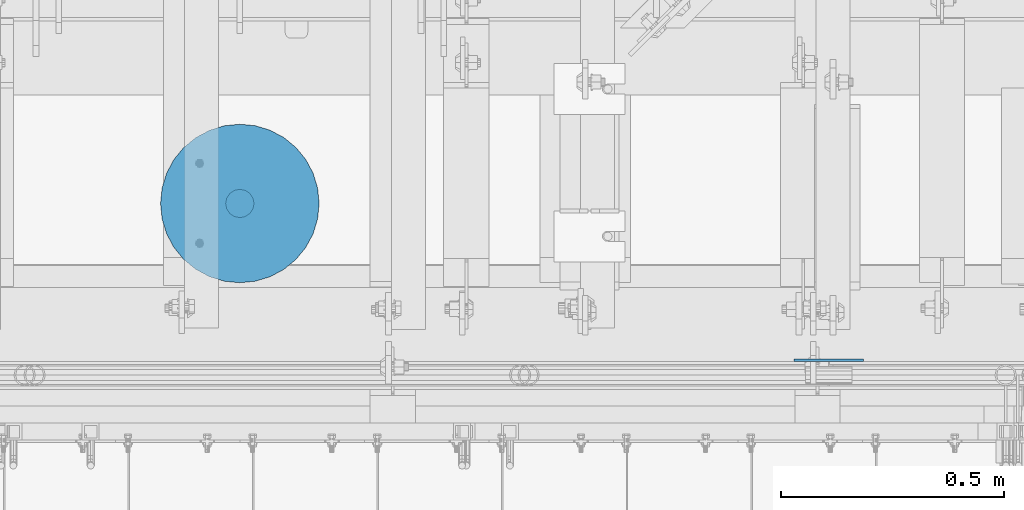
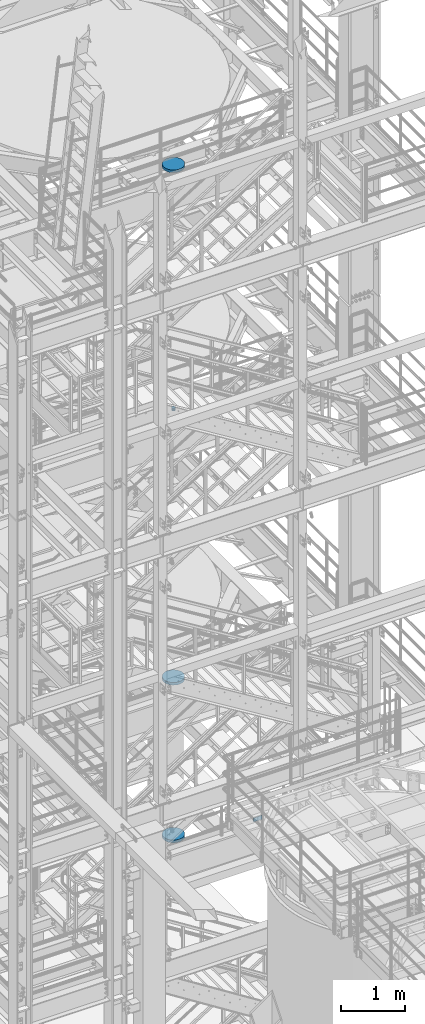
# One storey, part 827 of 1876: 5 columns, 5 elements without a shape of their own.
"""IFC2X3 building model written with IfcOpenShell, lengths in millimetres."""

from ifc_helpers import new_model, si_unit, frame, origin_with_axes, place, context, subcontext, project, spatial, faceted_brep, material, type_object, element, aggregate, save


model = new_model("IFC2X3")

# Units and contexts
model_context = context("Model", 3, precision=1e-05, world=origin_with_axes())
body_context = subcontext(model_context, "Body", "Model", "MODEL_VIEW")
ifc_project = project(units=[si_unit("LENGTHUNIT", "METRE", prefix="MILLI"), si_unit("AREAUNIT", "SQUARE_METRE"), si_unit("VOLUMEUNIT", "CUBIC_METRE"), si_unit("MASSUNIT", "GRAM", prefix="KILO"), si_unit("TIMEUNIT", "SECOND"), si_unit("PLANEANGLEUNIT", "RADIAN"), si_unit("SOLIDANGLEUNIT", "STERADIAN"), si_unit("THERMODYNAMICTEMPERATUREUNIT", "DEGREE_CELSIUS"), si_unit("LUMINOUSINTENSITYUNIT", "LUMEN")], contexts=[model_context])

# Site, building, storey
site_placement = place(None, origin_with_axes())
site = spatial("IfcSite", under=ifc_project, at=site_placement, CompositionType="ELEMENT")
building_placement = place(site_placement, origin_with_axes())
building = spatial("IfcBuilding", under=site, at=building_placement, Name="Undefined", CompositionType="ELEMENT")
storey_placement = place(building_placement, origin_with_axes())
storey = spatial("IfcBuildingStorey", under=building, at=storey_placement, Name="Undefined", CompositionType="ELEMENT", Elevation=0.0)

# Assembly, column
assembly_1_placement = place(storey_placement, origin_with_axes())
assembly_1 = element("IfcElementAssembly", 1, at=assembly_1_placement, inside=storey, Name="RAIL", AssemblyPlace="NOTDEFINED", PredefinedType="RIGID_FRAME")
ifc_material_1 = material(Name="STEEL/A36")
column_type_1 = type_object("IfcColumnType", PredefinedType="NOTDEFINED")
column_1_placement = place(assembly_1_placement, frame((5740.40000007866, -4621.21250114114, 5159.37500003018), z_axis=(1.0, 0.0, 0.0), x_axis=(0.0, 0.0, 1.0)))
column_1 = element("IfcColumn", 2, at=column_1_placement, type_object=column_type_1, material=ifc_material_1, Name="PLATE", context=body_context, shape_type="Brep", body=[
    faceted_brep([(0.0, 3.17500000000018, -77.7874999999999), (0.0, 3.17500000000018, 77.7874999999999), (76.1999999999971, 3.17500000000018, 77.7874999999999), (76.1999999999971, 3.17500000000018, -77.7874999999999), (0.0, -3.17500000000018, 77.7874999999999), (76.1999999999971, -3.17500000000018, 77.7874999999999), (0.0, -3.17500000000018, -77.7874999999999), (76.1999999999971, -3.17500000000018, -77.7874999999999)], [[[0, 1, 2, 3]], [[1, 4, 5, 2]], [[4, 6, 7, 5]], [[6, 0, 3, 7]], [[5, 7, 3, 2]], [[6, 4, 1, 0]]]),
])
aggregate(assembly_1, [column_1])

assembly_2_placement = place(storey_placement, origin_with_axes())
assembly_2 = element("IfcElementAssembly", 3, at=assembly_2_placement, inside=storey, Name="COLUMN", AssemblyPlace="NOTDEFINED", PredefinedType="REINFORCEMENT_UNIT")
ifc_material_2 = material(Name="CONCRETE/3000")
column_type_2 = type_object("IfcColumnType", PredefinedType="NOTDEFINED")
column_2_placement = place(assembly_2_placement, frame((4419.60227683873, -4269.64372558594, 17957.8), z_axis=(-1.0, 0.0, 0.0), x_axis=(0.0, 0.0, 1.0)))
column_2 = element("IfcColumn", 4, at=column_2_placement, type_object=column_type_2, material=ifc_material_2, Name="COLUMN", context=body_context, shape_type="Brep", body=[
    faceted_brep([(0.0, -177.8, 0.0), (0.0, -174.383622855695, -34.6870592544674), (50.7999999999993, -174.383622855695, -34.6870592544674), (50.7999999999993, -177.8, 0.0), (0.0, -164.265780880507, -68.0411142745133), (50.7999999999993, -164.265780880507, -68.0411142745133), (0.0, -147.835297067392, -98.7803874308856), (50.7999999999993, -147.835297067392, -98.7803874308856), (0.0, -125.723585694968, -125.723585694968), (50.7999999999993, -125.723585694968, -125.723585694968), (0.0, -98.7803874308856, -147.835297067392), (50.7999999999993, -98.7803874308856, -147.835297067392), (0.0, -68.0411142745133, -164.265780880507), (50.7999999999993, -68.0411142745133, -164.265780880507), (0.0, -34.6870592544674, -174.383622855695), (50.7999999999993, -34.6870592544674, -174.383622855695), (0.0, 0.0, -177.800003051758), (50.7999999999993, 0.0, -177.8), (0.0, 34.6870592544674, -174.383622855695), (50.7999999999993, 34.6870592544674, -174.383622855695), (0.0, 68.0411142745133, -164.265780880507), (50.7999999999993, 68.0411142745133, -164.265780880507), (0.0, 98.7803874308856, -147.835297067392), (50.7999999999993, 98.7803874308856, -147.835297067392), (0.0, 125.723585694968, -125.723585694968), (50.7999999999993, 125.723585694968, -125.723585694968), (0.0, 147.835297067392, -98.7803874308856), (50.7999999999993, 147.835297067392, -98.7803874308856), (0.0, 164.265780880507, -68.0411142745133), (50.7999999999993, 164.265780880507, -68.0411142745133), (0.0, 174.383622855694, -34.6870592544674), (50.7999999999993, 174.383622855694, -34.6870592544674), (0.0, 177.8, 0.0), (50.7999999999993, 177.8, 0.0), (0.0, 174.383622855694, 34.6870592544674), (50.7999999999993, 174.383622855694, 34.6870592544674), (0.0, 164.265780880507, 68.0411142745133), (50.7999999999993, 164.265780880507, 68.0411142745133), (0.0, 147.835297067392, 98.7803874308856), (50.7999999999993, 147.835297067392, 98.7803874308856), (0.0, 125.723585694968, 125.723585694968), (50.7999999999993, 125.723585694968, 125.723585694968), (0.0, 98.7803874308856, 147.835297067392), (50.7999999999993, 98.7803874308856, 147.835297067392), (0.0, 68.0411142745133, 164.265780880507), (50.7999999999993, 68.0411142745133, 164.265780880507), (0.0, 34.6870592544674, 174.383622855695), (50.7999999999993, 34.6870592544674, 174.383622855695), (0.0, 0.0, 177.800003051758), (50.7999999999993, 0.0, 177.8), (0.0, -34.6870592544674, 174.383622855695), (50.7999999999993, -34.6870592544674, 174.383622855695), (0.0, -68.0411142745133, 164.265780880507), (50.7999999999993, -68.0411142745133, 164.265780880507), (0.0, -98.7803874308856, 147.835297067392), (50.7999999999993, -98.7803874308856, 147.835297067392), (0.0, -125.723585694968, 125.723585694968), (50.7999999999993, -125.723585694968, 125.723585694968), (0.0, -147.835297067392, 98.7803874308856), (50.7999999999993, -147.835297067392, 98.7803874308856), (0.0, -164.265780880507, 68.0411142745133), (50.7999999999993, -164.265780880507, 68.0411142745133), (0.0, -174.383622855695, 34.6870592544674), (50.7999999999993, -174.383622855695, 34.6870592544674)], [[[0, 1, 2, 3]], [[1, 4, 5, 2]], [[4, 6, 7, 5]], [[6, 8, 9, 7]], [[8, 10, 11, 9]], [[10, 12, 13, 11]], [[12, 14, 15, 13]], [[14, 16, 17, 15]], [[16, 18, 19, 17]], [[18, 20, 21, 19]], [[20, 22, 23, 21]], [[22, 24, 25, 23]], [[24, 26, 27, 25]], [[26, 28, 29, 27]], [[28, 30, 31, 29]], [[30, 32, 33, 31]], [[32, 34, 35, 33]], [[34, 36, 37, 35]], [[36, 38, 39, 37]], [[38, 40, 41, 39]], [[40, 42, 43, 41]], [[42, 44, 45, 43]], [[44, 46, 47, 45]], [[46, 48, 49, 47]], [[48, 50, 51, 49]], [[50, 52, 53, 51]], [[52, 54, 55, 53]], [[54, 56, 57, 55]], [[56, 58, 59, 57]], [[58, 60, 61, 59]], [[60, 62, 63, 61]], [[62, 0, 3, 63]], [[5, 7, 9, 11, 13, 15, 17, 19, 21, 23, 25, 27, 29, 31, 33, 35, 37, 39, 41, 43, 45, 47, 49, 51, 53, 55, 57, 59, 61, 63, 3, 2]], [[62, 60, 58, 56, 54, 52, 50, 48, 46, 44, 42, 40, 38, 36, 34, 32, 30, 28, 26, 24, 22, 20, 18, 16, 14, 12, 10, 8, 6, 4, 1, 0]]]),
])
aggregate(assembly_2, [column_2])

assembly_3_placement = place(storey_placement, origin_with_axes())
assembly_3 = element("IfcElementAssembly", 5, at=assembly_3_placement, inside=storey, Name="COLUMN", AssemblyPlace="NOTDEFINED", PredefinedType="REINFORCEMENT_UNIT")
column_3_placement = place(assembly_3_placement, frame((4419.60227683873, -4269.64372558594, 8128.0), z_axis=(-1.0, 0.0, 0.0), x_axis=(0.0, 0.0, 1.0)))
column_3 = element("IfcColumn", 6, at=column_3_placement, type_object=column_type_2, material=ifc_material_2, Name="COLUMN", context=body_context, shape_type="Brep", body=[
    faceted_brep([(0.0, -177.8, 0.0), (0.0, -174.383622855695, -34.6870592544674), (50.7999999999993, -174.383622855695, -34.6870592544674), (50.7999999999993, -177.8, 0.0), (0.0, -164.265780880507, -68.0411142745133), (50.7999999999993, -164.265780880507, -68.0411142745133), (0.0, -147.835297067392, -98.7803874308856), (50.7999999999993, -147.835297067392, -98.7803874308856), (0.0, -125.723585694968, -125.723585694968), (50.7999999999993, -125.723585694968, -125.723585694968), (0.0, -98.7803874308856, -147.835297067392), (50.7999999999993, -98.7803874308856, -147.835297067392), (0.0, -68.0411142745133, -164.265780880507), (50.7999999999993, -68.0411142745133, -164.265780880507), (0.0, -34.6870592544674, -174.383622855695), (50.7999999999993, -34.6870592544674, -174.383622855695), (0.0, 0.0, -177.800003051758), (50.7999999999993, 0.0, -177.8), (0.0, 34.6870592544674, -174.383622855695), (50.7999999999993, 34.6870592544674, -174.383622855695), (0.0, 68.0411142745133, -164.265780880507), (50.7999999999993, 68.0411142745133, -164.265780880507), (0.0, 98.7803874308856, -147.835297067392), (50.7999999999993, 98.7803874308856, -147.835297067392), (0.0, 125.723585694968, -125.723585694968), (50.7999999999993, 125.723585694968, -125.723585694968), (0.0, 147.835297067392, -98.7803874308856), (50.7999999999993, 147.835297067392, -98.7803874308856), (0.0, 164.265780880507, -68.0411142745133), (50.7999999999993, 164.265780880507, -68.0411142745133), (0.0, 174.383622855694, -34.6870592544674), (50.7999999999993, 174.383622855694, -34.6870592544674), (0.0, 177.8, 0.0), (50.7999999999993, 177.8, 0.0), (0.0, 174.383622855694, 34.6870592544674), (50.7999999999993, 174.383622855694, 34.6870592544674), (0.0, 164.265780880507, 68.0411142745133), (50.7999999999993, 164.265780880507, 68.0411142745133), (0.0, 147.835297067392, 98.7803874308856), (50.7999999999993, 147.835297067392, 98.7803874308856), (0.0, 125.723585694968, 125.723585694968), (50.7999999999993, 125.723585694968, 125.723585694968), (0.0, 98.7803874308856, 147.835297067392), (50.7999999999993, 98.7803874308856, 147.835297067392), (0.0, 68.0411142745133, 164.265780880507), (50.7999999999993, 68.0411142745133, 164.265780880507), (0.0, 34.6870592544674, 174.383622855695), (50.7999999999993, 34.6870592544674, 174.383622855695), (0.0, 0.0, 177.800003051758), (50.7999999999993, 0.0, 177.8), (0.0, -34.6870592544674, 174.383622855695), (50.7999999999993, -34.6870592544674, 174.383622855695), (0.0, -68.0411142745133, 164.265780880507), (50.7999999999993, -68.0411142745133, 164.265780880507), (0.0, -98.7803874308856, 147.835297067392), (50.7999999999993, -98.7803874308856, 147.835297067392), (0.0, -125.723585694968, 125.723585694968), (50.7999999999993, -125.723585694968, 125.723585694968), (0.0, -147.835297067392, 98.7803874308856), (50.7999999999993, -147.835297067392, 98.7803874308856), (0.0, -164.265780880507, 68.0411142745133), (50.7999999999993, -164.265780880507, 68.0411142745133), (0.0, -174.383622855695, 34.6870592544674), (50.7999999999993, -174.383622855695, 34.6870592544674)], [[[0, 1, 2, 3]], [[1, 4, 5, 2]], [[4, 6, 7, 5]], [[6, 8, 9, 7]], [[8, 10, 11, 9]], [[10, 12, 13, 11]], [[12, 14, 15, 13]], [[14, 16, 17, 15]], [[16, 18, 19, 17]], [[18, 20, 21, 19]], [[20, 22, 23, 21]], [[22, 24, 25, 23]], [[24, 26, 27, 25]], [[26, 28, 29, 27]], [[28, 30, 31, 29]], [[30, 32, 33, 31]], [[32, 34, 35, 33]], [[34, 36, 37, 35]], [[36, 38, 39, 37]], [[38, 40, 41, 39]], [[40, 42, 43, 41]], [[42, 44, 45, 43]], [[44, 46, 47, 45]], [[46, 48, 49, 47]], [[48, 50, 51, 49]], [[50, 52, 53, 51]], [[52, 54, 55, 53]], [[54, 56, 57, 55]], [[56, 58, 59, 57]], [[58, 60, 61, 59]], [[60, 62, 63, 61]], [[62, 0, 3, 63]], [[5, 7, 9, 11, 13, 15, 17, 19, 21, 23, 25, 27, 29, 31, 33, 35, 37, 39, 41, 43, 45, 47, 49, 51, 53, 55, 57, 59, 61, 63, 3, 2]], [[62, 60, 58, 56, 54, 52, 50, 48, 46, 44, 42, 40, 38, 36, 34, 32, 30, 28, 26, 24, 22, 20, 18, 16, 14, 12, 10, 8, 6, 4, 1, 0]]]),
])
aggregate(assembly_3, [column_3])

assembly_4_placement = place(storey_placement, origin_with_axes())
assembly_4 = element("IfcElementAssembly", 7, at=assembly_4_placement, inside=storey, Name="COLUMN", AssemblyPlace="NOTDEFINED", PredefinedType="REINFORCEMENT_UNIT")
column_4_placement = place(assembly_4_placement, frame((4419.60227683873, -4269.64372558594, 5105.4), z_axis=(-1.0, 0.0, 0.0), x_axis=(0.0, 0.0, 1.0)))
column_4 = element("IfcColumn", 8, at=column_4_placement, type_object=column_type_2, material=ifc_material_2, Name="COLUMN", context=body_context, shape_type="Brep", body=[
    faceted_brep([(0.0, -177.8, 0.0), (0.0, -174.383622855695, -34.6870592544674), (50.7999999999993, -174.383622855695, -34.6870592544674), (50.7999999999993, -177.8, 0.0), (0.0, -164.265780880507, -68.0411142745133), (50.7999999999993, -164.265780880507, -68.0411142745133), (0.0, -147.835297067392, -98.7803874308856), (50.7999999999993, -147.835297067392, -98.7803874308856), (0.0, -125.723585694968, -125.723585694968), (50.7999999999993, -125.723585694968, -125.723585694968), (0.0, -98.7803874308856, -147.835297067392), (50.7999999999993, -98.7803874308856, -147.835297067392), (0.0, -68.0411142745133, -164.265780880507), (50.7999999999993, -68.0411142745133, -164.265780880507), (0.0, -34.6870592544674, -174.383622855695), (50.7999999999993, -34.6870592544674, -174.383622855695), (0.0, 0.0, -177.800003051758), (50.7999999999993, 0.0, -177.8), (0.0, 34.6870592544674, -174.383622855695), (50.7999999999993, 34.6870592544674, -174.383622855695), (0.0, 68.0411142745133, -164.265780880507), (50.7999999999993, 68.0411142745133, -164.265780880507), (0.0, 98.7803874308856, -147.835297067392), (50.7999999999993, 98.7803874308856, -147.835297067392), (0.0, 125.723585694968, -125.723585694968), (50.7999999999993, 125.723585694968, -125.723585694968), (0.0, 147.835297067392, -98.7803874308856), (50.7999999999993, 147.835297067392, -98.7803874308856), (0.0, 164.265780880507, -68.0411142745133), (50.7999999999993, 164.265780880507, -68.0411142745133), (0.0, 174.383622855694, -34.6870592544674), (50.7999999999993, 174.383622855694, -34.6870592544674), (0.0, 177.8, 0.0), (50.7999999999993, 177.8, 0.0), (0.0, 174.383622855694, 34.6870592544674), (50.7999999999993, 174.383622855694, 34.6870592544674), (0.0, 164.265780880507, 68.0411142745133), (50.7999999999993, 164.265780880507, 68.0411142745133), (0.0, 147.835297067392, 98.7803874308856), (50.7999999999993, 147.835297067392, 98.7803874308856), (0.0, 125.723585694968, 125.723585694968), (50.7999999999993, 125.723585694968, 125.723585694968), (0.0, 98.7803874308856, 147.835297067392), (50.7999999999993, 98.7803874308856, 147.835297067392), (0.0, 68.0411142745133, 164.265780880507), (50.7999999999993, 68.0411142745133, 164.265780880507), (0.0, 34.6870592544674, 174.383622855695), (50.7999999999993, 34.6870592544674, 174.383622855695), (0.0, 0.0, 177.800003051758), (50.7999999999993, 0.0, 177.8), (0.0, -34.6870592544674, 174.383622855695), (50.7999999999993, -34.6870592544674, 174.383622855695), (0.0, -68.0411142745133, 164.265780880507), (50.7999999999993, -68.0411142745133, 164.265780880507), (0.0, -98.7803874308856, 147.835297067392), (50.7999999999993, -98.7803874308856, 147.835297067392), (0.0, -125.723585694968, 125.723585694968), (50.7999999999993, -125.723585694968, 125.723585694968), (0.0, -147.835297067392, 98.7803874308856), (50.7999999999993, -147.835297067392, 98.7803874308856), (0.0, -164.265780880507, 68.0411142745133), (50.7999999999993, -164.265780880507, 68.0411142745133), (0.0, -174.383622855695, 34.6870592544674), (50.7999999999993, -174.383622855695, 34.6870592544674)], [[[0, 1, 2, 3]], [[1, 4, 5, 2]], [[4, 6, 7, 5]], [[6, 8, 9, 7]], [[8, 10, 11, 9]], [[10, 12, 13, 11]], [[12, 14, 15, 13]], [[14, 16, 17, 15]], [[16, 18, 19, 17]], [[18, 20, 21, 19]], [[20, 22, 23, 21]], [[22, 24, 25, 23]], [[24, 26, 27, 25]], [[26, 28, 29, 27]], [[28, 30, 31, 29]], [[30, 32, 33, 31]], [[32, 34, 35, 33]], [[34, 36, 37, 35]], [[36, 38, 39, 37]], [[38, 40, 41, 39]], [[40, 42, 43, 41]], [[42, 44, 45, 43]], [[44, 46, 47, 45]], [[46, 48, 49, 47]], [[48, 50, 51, 49]], [[50, 52, 53, 51]], [[52, 54, 55, 53]], [[54, 56, 57, 55]], [[56, 58, 59, 57]], [[58, 60, 61, 59]], [[60, 62, 63, 61]], [[62, 0, 3, 63]], [[5, 7, 9, 11, 13, 15, 17, 19, 21, 23, 25, 27, 29, 31, 33, 35, 37, 39, 41, 43, 45, 47, 49, 51, 53, 55, 57, 59, 61, 63, 3, 2]], [[62, 60, 58, 56, 54, 52, 50, 48, 46, 44, 42, 40, 38, 36, 34, 32, 30, 28, 26, 24, 22, 20, 18, 16, 14, 12, 10, 8, 6, 4, 1, 0]]]),
])
aggregate(assembly_4, [column_4])

assembly_5_placement = place(storey_placement, origin_with_axes())
assembly_5 = element("IfcElementAssembly", 9, at=assembly_5_placement, inside=storey, Name="COLUMN", AssemblyPlace="NOTDEFINED", PredefinedType="REINFORCEMENT_UNIT")
column_type_3 = type_object("IfcColumnType", PredefinedType="NOTDEFINED")
column_5_placement = place(assembly_5_placement, frame((4419.60227683873, -4269.64372558594, 13284.2), z_axis=(-1.0, 0.0, 0.0), x_axis=(0.0, 0.0, 1.0)))
column_5 = element("IfcColumn", 10, at=column_5_placement, type_object=column_type_3, material=ifc_material_2, Name="COLUMN", context=body_context, shape_type="Brep", body=[
    faceted_brep([(0.0, -31.75, 0.0), (0.0, -29.3331751572332, -12.1501989775916), (50.7999999999993, -29.3331751572332, -12.1501989775916), (50.7999999999993, -31.75, 0.0), (0.0, -22.4506403026726, -22.4506403026726), (50.7999999999993, -22.4506403026726, -22.4506403026726), (0.0, -12.1501989775916, -29.3331751572332), (50.7999999999993, -12.1501989775916, -29.3331751572332), (0.0, 0.0, -31.75), (50.7999999999993, 0.0, -31.75), (0.0, 12.1501989775916, -29.3331751572332), (50.7999999999993, 12.1501989775916, -29.3331751572332), (0.0, 22.4506403026726, -22.4506403026726), (50.7999999999993, 22.4506403026726, -22.4506403026726), (0.0, 29.3331751572332, -12.1501989775916), (50.7999999999993, 29.3331751572332, -12.1501989775916), (0.0, 31.75, 0.0), (50.7999999999993, 31.75, 0.0), (0.0, 29.3331751572332, 12.1501989775916), (50.7999999999993, 29.3331751572332, 12.1501989775916), (0.0, 22.4506403026726, 22.4506403026726), (50.7999999999993, 22.4506403026726, 22.4506403026726), (0.0, 12.1501989775916, 29.3331751572332), (50.7999999999993, 12.1501989775916, 29.3331751572332), (0.0, 0.0, 31.75), (50.7999999999993, 0.0, 31.75), (0.0, -12.1501989775916, 29.3331751572332), (50.7999999999993, -12.1501989775916, 29.3331751572332), (0.0, -22.4506403026726, 22.4506403026726), (50.7999999999993, -22.4506403026726, 22.4506403026726), (0.0, -29.3331751572332, 12.1501989775916), (50.7999999999993, -29.3331751572332, 12.1501989775916)], [[[0, 1, 2, 3]], [[1, 4, 5, 2]], [[4, 6, 7, 5]], [[6, 8, 9, 7]], [[8, 10, 11, 9]], [[10, 12, 13, 11]], [[12, 14, 15, 13]], [[14, 16, 17, 15]], [[16, 18, 19, 17]], [[18, 20, 21, 19]], [[20, 22, 23, 21]], [[22, 24, 25, 23]], [[24, 26, 27, 25]], [[26, 28, 29, 27]], [[28, 30, 31, 29]], [[30, 0, 3, 31]], [[5, 7, 9, 11, 13, 15, 17, 19, 21, 23, 25, 27, 29, 31, 3, 2]], [[30, 28, 26, 24, 22, 20, 18, 16, 14, 12, 10, 8, 6, 4, 1, 0]]]),
])
aggregate(assembly_5, [column_5])

save(model, "model.ifc")
